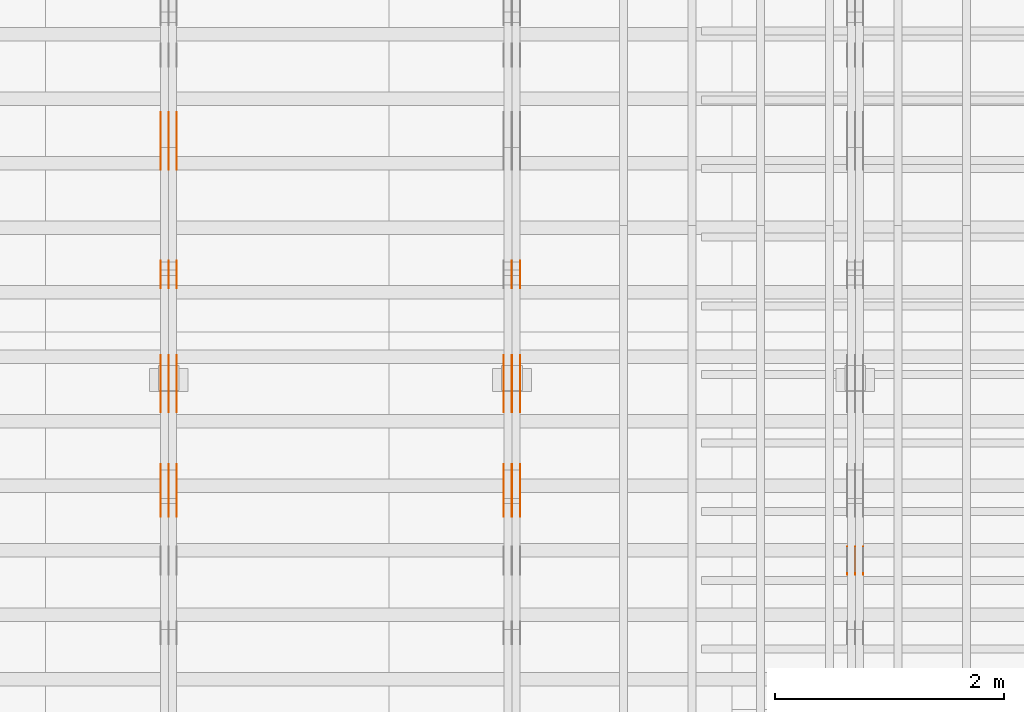
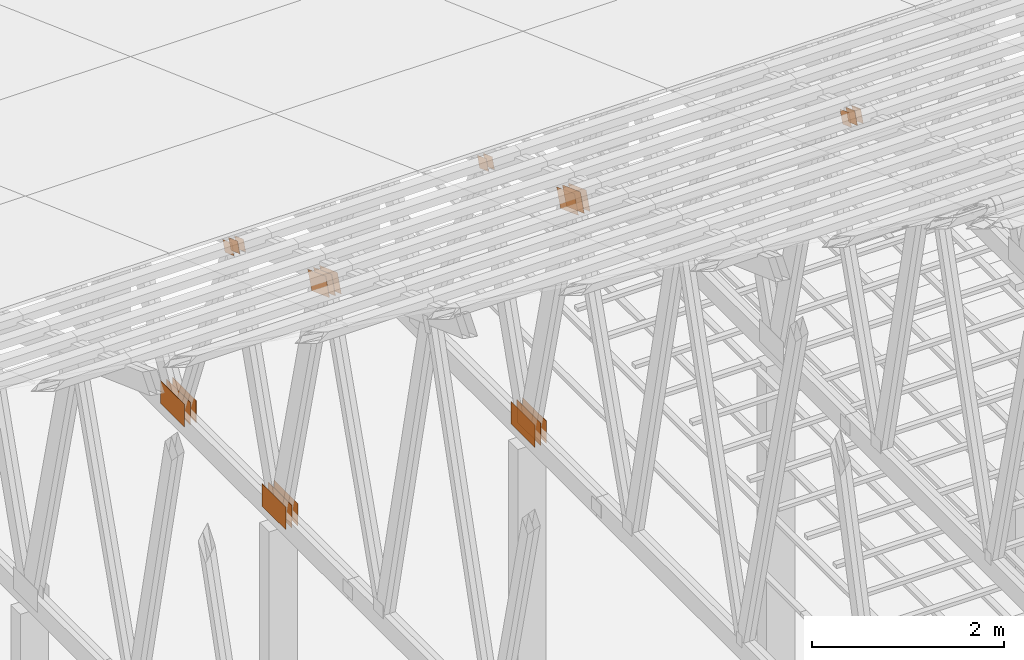
# One storey, part 163 of 189: 30 proxies.
"""IFC2X3 building model written with IfcOpenShell, lengths in millimetres."""

from ifc_helpers import new_model, entity, si_unit, converted_unit, derived_unit, direction, frame, origin, origin_2d_with_axis, place, context, subcontext, project, spatial, polyline, rectangle, outline, extrude, source, transform, mapped, material, type_object, type_shapes, element, save


model = new_model("IFC2X3")

# Units and contexts
model_context = context("Model", 3, precision=0.01, world=origin(), true_north=direction((6.12303176911189e-17, 1.0)))
body_context = subcontext(model_context, "Body", "Model", "MODEL_VIEW")
ifc_project = project(units=[si_unit("LENGTHUNIT", "METRE", prefix="MILLI"), si_unit("AREAUNIT", "SQUARE_METRE"), si_unit("VOLUMEUNIT", "CUBIC_METRE"), converted_unit("PLANEANGLEUNIT", "DEGREE", entity("IfcRatioMeasure", 0.0174532925199433), si_unit("PLANEANGLEUNIT", "RADIAN"), dimensions=[0, 0, 0, 0, 0, 0, 0]), si_unit("MASSUNIT", "GRAM", prefix="KILO"), derived_unit("MASSDENSITYUNIT", [(si_unit("MASSUNIT", "GRAM", prefix="KILO"), 1), (si_unit("LENGTHUNIT", "METRE"), -3)]), si_unit("TIMEUNIT", "SECOND"), si_unit("FREQUENCYUNIT", "HERTZ"), si_unit("THERMODYNAMICTEMPERATUREUNIT", "DEGREE_CELSIUS"), derived_unit("THERMALTRANSMITTANCEUNIT", [(si_unit("MASSUNIT", "GRAM", prefix="KILO"), 1), (si_unit("THERMODYNAMICTEMPERATUREUNIT", "KELVIN"), -1), (si_unit("TIMEUNIT", "SECOND"), -3)]), derived_unit("VOLUMETRICFLOWRATEUNIT", [(si_unit("LENGTHUNIT", "METRE"), 3), (si_unit("TIMEUNIT", "SECOND"), -1)]), si_unit("ELECTRICCURRENTUNIT", "AMPERE"), si_unit("ELECTRICVOLTAGEUNIT", "VOLT"), si_unit("POWERUNIT", "WATT"), si_unit("FORCEUNIT", "NEWTON"), si_unit("ILLUMINANCEUNIT", "LUX"), si_unit("LUMINOUSFLUXUNIT", "LUMEN"), si_unit("LUMINOUSINTENSITYUNIT", "CANDELA"), derived_unit("USERDEFINED", [(si_unit("MASSUNIT", "GRAM", prefix="KILO"), -1), (si_unit("LENGTHUNIT", "METRE"), -2), (si_unit("TIMEUNIT", "SECOND"), 3), (si_unit("LUMINOUSFLUXUNIT", "LUMEN"), 1)]), derived_unit("LINEARVELOCITYUNIT", [(si_unit("LENGTHUNIT", "METRE"), 1), (si_unit("TIMEUNIT", "SECOND"), -1)]), si_unit("PRESSUREUNIT", "PASCAL"), derived_unit("USERDEFINED", [(si_unit("LENGTHUNIT", "METRE"), -2), (si_unit("MASSUNIT", "GRAM", prefix="KILO"), 1), (si_unit("TIMEUNIT", "SECOND"), -2)])], contexts=[model_context])

# Site, building, storey
site_placement = place(None, origin())
site = spatial("IfcSite", under=ifc_project, at=site_placement, CompositionType="ELEMENT")
building_placement = place(site_placement, origin())
building = spatial("IfcBuilding", under=site, at=building_placement, CompositionType="ELEMENT")
storey_placement = place(building_placement, origin())
storey = spatial("IfcBuildingStorey", under=building, at=storey_placement, Name="Default", CompositionType="ELEMENT", Elevation=0.0)

# Proxies
ifc_material_1 = material(Name="IfcSurfaceStyle #242780")
building_element_proxy_type_1 = type_object("IfcBuildingElementProxyType", PredefinedType="NOTDEFINED", material=ifc_material_1)
shared_shape_1 = source(origin(), body_context, "Body", "SweptSolid", [
    extrude(outline(polyline([(-100.000115120732, -83.9999347094754), (99.9997648860521, -83.9999347094754), (100.000156871236, 83.9999347094753), (-99.9998066365565, 83.9999347094753), (-100.000115120732, -83.9999347094754)])), frame((100.000156871236, 84.0000502182443, 0.0), z_axis=(0.0, 0.0, 1.0), x_axis=(-1.0, 0.0, 0.0)), (0.0, 0.0, 1.0), 1.3),
])
type_shapes(building_element_proxy_type_1, [shared_shape_1])
proxy_1_placement = place(building_placement, frame((45301.3, 19216.0995831719, 3923.28093386695), z_axis=(-1.0, 0.0, 0.0), x_axis=(0.0, -0.939692620785908, 0.342020143325669)))
element("IfcBuildingElementProxy", 1, at=proxy_1_placement, inside=storey, type_object=building_element_proxy_type_1, material=ifc_material_1, context=body_context, shape_type="MappedRepresentation", body=[
    mapped(shared_shape_1, transform((0.0, 0.0, 0.0), scale=1.0)),
])
ifc_material_2 = material(Name="IfcSurfaceStyle #242723")
building_element_proxy_type_2 = type_object("IfcBuildingElementProxyType", PredefinedType="NOTDEFINED", material=ifc_material_2)
shared_shape_2 = source(origin(), body_context, "Body", "SweptSolid", [
    extrude(outline(polyline([(-100.000115120732, -83.9999347094754), (99.9997648860521, -83.9999347094754), (100.000156871236, 83.9999347094753), (-99.9998066365565, 83.9999347094753), (-100.000115120732, -83.9999347094754)])), frame((100.000156871236, 84.0000502182443, 0.0), z_axis=(0.0, 0.0, 1.0), x_axis=(-1.0, 0.0, 0.0)), (0.0, 0.0, 1.0), 1.29999999999998),
])
type_shapes(building_element_proxy_type_2, [shared_shape_2])
proxy_2_placement = place(building_placement, frame((45230.0, 19216.0995831719, 3923.28093386695), z_axis=(-1.0, 0.0, 0.0), x_axis=(0.0, -0.939692620785908, 0.342020143325669)))
element("IfcBuildingElementProxy", 2, at=proxy_2_placement, inside=storey, type_object=building_element_proxy_type_2, material=ifc_material_2, context=body_context, shape_type="MappedRepresentation", body=[
    mapped(shared_shape_2, transform((0.0, 0.0, 0.0), scale=1.0)),
])
ifc_material_3 = material(Name="IfcSurfaceStyle #242666")
building_element_proxy_type_3 = type_object("IfcBuildingElementProxyType", PredefinedType="NOTDEFINED", material=ifc_material_3)
shared_shape_3 = source(origin(), body_context, "Body", "SweptSolid", [
    extrude(outline(polyline([(-100.000115120732, -83.9999347094754), (99.9997648860521, -83.9999347094754), (100.000156871236, 83.9999347094753), (-99.9998066365565, 83.9999347094753), (-100.000115120732, -83.9999347094754)])), frame((100.000156871236, 84.0000502182443, 0.0), z_axis=(0.0, 0.0, 1.0), x_axis=(-1.0, 0.0, 0.0)), (0.0, 0.0, 1.0), 1.29999999999998),
])
type_shapes(building_element_proxy_type_3, [shared_shape_3])
proxy_3_placement = place(building_placement, frame((45231.3, 19216.0995831719, 3923.28093386695), z_axis=(-1.0, 0.0, 0.0), x_axis=(0.0, -0.939692620785908, 0.342020143325669)))
element("IfcBuildingElementProxy", 3, at=proxy_3_placement, inside=storey, type_object=building_element_proxy_type_3, material=ifc_material_3, context=body_context, shape_type="MappedRepresentation", body=[
    mapped(shared_shape_3, transform((0.0, 0.0, 0.0), scale=1.0)),
])
ifc_material_4 = material(Name="IfcSurfaceStyle #242609")
building_element_proxy_type_4 = type_object("IfcBuildingElementProxyType", PredefinedType="NOTDEFINED", material=ifc_material_4)
shared_shape_4 = source(origin(), body_context, "Body", "SweptSolid", [
    extrude(outline(polyline([(-100.000115120732, -83.9999347094754), (99.9997648860521, -83.9999347094754), (100.000156871236, 83.9999347094753), (-99.9998066365565, 83.9999347094753), (-100.000115120732, -83.9999347094754)])), frame((100.000156871236, 84.0000502182443, 0.0), z_axis=(0.0, 0.0, 1.0), x_axis=(-1.0, 0.0, 0.0)), (0.0, 0.0, 1.0), 1.29999999999999),
])
type_shapes(building_element_proxy_type_4, [shared_shape_4])
proxy_4_placement = place(building_placement, frame((45160.0, 19216.0995831719, 3923.28093386695), z_axis=(-1.0, 0.0, 0.0), x_axis=(0.0, -0.939692620785908, 0.342020143325669)))
element("IfcBuildingElementProxy", 4, at=proxy_4_placement, inside=storey, type_object=building_element_proxy_type_4, material=ifc_material_4, context=body_context, shape_type="MappedRepresentation", body=[
    mapped(shared_shape_4, transform((0.0, 0.0, 0.0), scale=1.0)),
])
ifc_material_5 = material(Name="IfcSurfaceStyle #234394")
building_element_proxy_type_5 = type_object("IfcBuildingElementProxyType", PredefinedType="NOTDEFINED", material=ifc_material_5)
shared_shape_5 = source(origin(), body_context, "Body", "SweptSolid", [
    extrude(outline(polyline([(-200.000344770935, -119.999765965113), (199.999582244654, -119.999765965113), (200.000344770935, 119.999765965113), (-199.999582244653, 119.999765965113), (-200.000344770935, -119.999765965113)])), frame((200.000344770935, 119.999990805307, 0.0), z_axis=(0.0, 0.0, 1.0), x_axis=(-1.0, 0.0, 0.0)), (0.0, 0.0, 1.0), 1.29999999999999),
])
type_shapes(building_element_proxy_type_5, [shared_shape_5])
proxy_5_placement = place(building_placement, frame((42301.3, 19620.1777846684, 3837.77137841443), z_axis=(-1.0, 0.0, 0.0), x_axis=(0.0, 0.939692620785908, -0.342020143325669)))
element("IfcBuildingElementProxy", 5, at=proxy_5_placement, inside=storey, type_object=building_element_proxy_type_5, material=ifc_material_5, context=body_context, shape_type="MappedRepresentation", body=[
    mapped(shared_shape_5, transform((0.0, 0.0, 0.0), scale=1.0)),
])
ifc_material_6 = material(Name="IfcSurfaceStyle #234337")
building_element_proxy_type_6 = type_object("IfcBuildingElementProxyType", PredefinedType="NOTDEFINED", material=ifc_material_6)
shared_shape_6 = source(origin(), body_context, "Body", "SweptSolid", [
    extrude(outline(polyline([(-200.000344770935, -119.999765965113), (199.999582244654, -119.999765965113), (200.000344770935, 119.999765965113), (-199.999582244653, 119.999765965113), (-200.000344770935, -119.999765965113)])), frame((200.000344770935, 119.999990805307, 0.0), z_axis=(0.0, 0.0, 1.0), x_axis=(-1.0, 0.0, 0.0)), (0.0, 0.0, 1.0), 1.29999999999997),
])
type_shapes(building_element_proxy_type_6, [shared_shape_6])
proxy_6_placement = place(building_placement, frame((42230.0, 19620.1777846684, 3837.77137841443), z_axis=(-1.0, 0.0, 0.0), x_axis=(0.0, 0.939692620785908, -0.342020143325669)))
element("IfcBuildingElementProxy", 6, at=proxy_6_placement, inside=storey, type_object=building_element_proxy_type_6, material=ifc_material_6, context=body_context, shape_type="MappedRepresentation", body=[
    mapped(shared_shape_6, transform((0.0, 0.0, 0.0), scale=1.0)),
])
ifc_material_7 = material(Name="IfcSurfaceStyle #234280")
building_element_proxy_type_7 = type_object("IfcBuildingElementProxyType", PredefinedType="NOTDEFINED", material=ifc_material_7)
shared_shape_7 = source(origin(), body_context, "Body", "SweptSolid", [
    extrude(outline(polyline([(-200.000344770935, -119.999765965113), (199.999582244654, -119.999765965113), (200.000344770935, 119.999765965113), (-199.999582244653, 119.999765965113), (-200.000344770935, -119.999765965113)])), frame((200.000344770935, 119.999990805307, 0.0), z_axis=(0.0, 0.0, 1.0), x_axis=(-1.0, 0.0, 0.0)), (0.0, 0.0, 1.0), 1.29999999999997),
])
type_shapes(building_element_proxy_type_7, [shared_shape_7])
proxy_7_placement = place(building_placement, frame((42231.3, 19620.1777846684, 3837.77137841443), z_axis=(-1.0, 0.0, 0.0), x_axis=(0.0, 0.939692620785908, -0.342020143325669)))
element("IfcBuildingElementProxy", 7, at=proxy_7_placement, inside=storey, type_object=building_element_proxy_type_7, material=ifc_material_7, context=body_context, shape_type="MappedRepresentation", body=[
    mapped(shared_shape_7, transform((0.0, 0.0, 0.0), scale=1.0)),
])
ifc_material_8 = material(Name="IfcSurfaceStyle #234223")
building_element_proxy_type_8 = type_object("IfcBuildingElementProxyType", PredefinedType="NOTDEFINED", material=ifc_material_8)
shared_shape_8 = source(origin(), body_context, "Body", "SweptSolid", [
    extrude(outline(polyline([(-200.000344770935, -119.999765965113), (199.999582244654, -119.999765965113), (200.000344770935, 119.999765965113), (-199.999582244653, 119.999765965113), (-200.000344770935, -119.999765965113)])), frame((200.000344770935, 119.999990805307, 0.0), z_axis=(0.0, 0.0, 1.0), x_axis=(-1.0, 0.0, 0.0)), (0.0, 0.0, 1.0), 1.29999999999998),
])
type_shapes(building_element_proxy_type_8, [shared_shape_8])
proxy_8_placement = place(building_placement, frame((42160.0, 19620.1777846684, 3837.77137841443), z_axis=(-1.0, 0.0, 0.0), x_axis=(0.0, 0.939692620785908, -0.342020143325669)))
element("IfcBuildingElementProxy", 8, at=proxy_8_placement, inside=storey, type_object=building_element_proxy_type_8, material=ifc_material_8, context=body_context, shape_type="MappedRepresentation", body=[
    mapped(shared_shape_8, transform((0.0, 0.0, 0.0), scale=1.0)),
])
ifc_material_9 = material(Name="IfcSurfaceStyle #234166")
building_element_proxy_type_9 = type_object("IfcBuildingElementProxyType", PredefinedType="NOTDEFINED", material=ifc_material_9)
shared_shape_9 = source(origin(), body_context, "Body", "SweptSolid", [
    extrude(rectangle(XDim=500.0, YDim=288.0, at=origin_2d_with_axis()), frame((250.0, 144.0, 0.0), z_axis=(0.0, 0.0, 1.0), x_axis=(-1.0, 0.0, 0.0)), (0.0, 0.0, 1.0), 1.29999999999998),
])
type_shapes(building_element_proxy_type_9, [shared_shape_9])
proxy_9_placement = place(building_placement, frame((42301.3, 20948.0908203125, 101.0), z_axis=(-1.0, 0.0, 0.0), x_axis=(0.0, -1.0, 0.0)))
element("IfcBuildingElementProxy", 9, at=proxy_9_placement, inside=storey, type_object=building_element_proxy_type_9, material=ifc_material_9, context=body_context, shape_type="MappedRepresentation", body=[
    mapped(shared_shape_9, transform((0.0, 0.0, 0.0), scale=1.0)),
])
ifc_material_10 = material(Name="IfcSurfaceStyle #234109")
building_element_proxy_type_10 = type_object("IfcBuildingElementProxyType", PredefinedType="NOTDEFINED", material=ifc_material_10)
shared_shape_10 = source(origin(), body_context, "Body", "SweptSolid", [
    extrude(rectangle(XDim=500.0, YDim=288.0, at=origin_2d_with_axis()), frame((250.0, 144.0, 0.0), z_axis=(0.0, 0.0, 1.0), x_axis=(-1.0, 0.0, 0.0)), (0.0, 0.0, 1.0), 1.29999999999997),
])
type_shapes(building_element_proxy_type_10, [shared_shape_10])
proxy_10_placement = place(building_placement, frame((42230.0, 20948.0908203125, 101.0), z_axis=(-1.0, 0.0, 0.0), x_axis=(0.0, -1.0, 0.0)))
element("IfcBuildingElementProxy", 10, at=proxy_10_placement, inside=storey, type_object=building_element_proxy_type_10, material=ifc_material_10, context=body_context, shape_type="MappedRepresentation", body=[
    mapped(shared_shape_10, transform((0.0, 0.0, 0.0), scale=1.0)),
])
ifc_material_11 = material(Name="IfcSurfaceStyle #234052")
building_element_proxy_type_11 = type_object("IfcBuildingElementProxyType", PredefinedType="NOTDEFINED", material=ifc_material_11)
shared_shape_11 = source(origin(), body_context, "Body", "SweptSolid", [
    extrude(rectangle(XDim=500.0, YDim=288.0, at=origin_2d_with_axis()), frame((250.0, 144.0, 0.0), z_axis=(0.0, 0.0, 1.0), x_axis=(-1.0, 0.0, 0.0)), (0.0, 0.0, 1.0), 1.29999999999997),
])
type_shapes(building_element_proxy_type_11, [shared_shape_11])
proxy_11_placement = place(building_placement, frame((42231.3, 20948.0908203125, 101.0), z_axis=(-1.0, 0.0, 0.0), x_axis=(0.0, -1.0, 0.0)))
element("IfcBuildingElementProxy", 11, at=proxy_11_placement, inside=storey, type_object=building_element_proxy_type_11, material=ifc_material_11, context=body_context, shape_type="MappedRepresentation", body=[
    mapped(shared_shape_11, transform((0.0, 0.0, 0.0), scale=1.0)),
])
ifc_material_12 = material(Name="IfcSurfaceStyle #233995")
building_element_proxy_type_12 = type_object("IfcBuildingElementProxyType", PredefinedType="NOTDEFINED", material=ifc_material_12)
shared_shape_12 = source(origin(), body_context, "Body", "SweptSolid", [
    extrude(rectangle(XDim=500.0, YDim=288.0, at=origin_2d_with_axis()), frame((250.0, 144.0, 0.0), z_axis=(0.0, 0.0, 1.0), x_axis=(-1.0, 0.0, 0.0)), (0.0, 0.0, 1.0), 1.29999999999997),
])
type_shapes(building_element_proxy_type_12, [shared_shape_12])
proxy_12_placement = place(building_placement, frame((42160.0, 20948.0908203125, 101.0), z_axis=(-1.0, 0.0, 0.0), x_axis=(0.0, -1.0, 0.0)))
element("IfcBuildingElementProxy", 12, at=proxy_12_placement, inside=storey, type_object=building_element_proxy_type_12, material=ifc_material_12, context=body_context, shape_type="MappedRepresentation", body=[
    mapped(shared_shape_12, transform((0.0, 0.0, 0.0), scale=1.0)),
])
ifc_material_13 = material(Name="IfcSurfaceStyle #233482")
building_element_proxy_type_13 = type_object("IfcBuildingElementProxyType", PredefinedType="NOTDEFINED", material=ifc_material_13)
shared_shape_13 = source(origin(), body_context, "Body", "SweptSolid", [
    extrude(outline(polyline([(-100.000279336925, -71.9999636698844), (100.000143005157, -71.9999636698844), (100.00004991978, 71.9999636698844), (-99.9999135880125, 71.9999636698845), (-100.000279336925, -71.9999636698844)])), frame((100.000143005157, 72.0001110824169, 0.0), z_axis=(0.0, 0.0, 1.0), x_axis=(-1.0, 0.0, 0.0)), (0.0, 0.0, 1.0), 1.3),
])
type_shapes(building_element_proxy_type_13, [shared_shape_13])
proxy_13_placement = place(building_placement, frame((42301.3, 21584.0819808932, 3071.51551466861), z_axis=(-1.0, 0.0, 0.0), x_axis=(0.0, 0.939692620785908, -0.342020143325669)))
element("IfcBuildingElementProxy", 13, at=proxy_13_placement, inside=storey, type_object=building_element_proxy_type_13, material=ifc_material_13, context=body_context, shape_type="MappedRepresentation", body=[
    mapped(shared_shape_13, transform((0.0, 0.0, 0.0), scale=1.0)),
])
ifc_material_14 = material(Name="IfcSurfaceStyle #233425")
building_element_proxy_type_14 = type_object("IfcBuildingElementProxyType", PredefinedType="NOTDEFINED", material=ifc_material_14)
shared_shape_14 = source(origin(), body_context, "Body", "SweptSolid", [
    extrude(outline(polyline([(-100.000279336925, -71.9999636698844), (100.000143005157, -71.9999636698844), (100.00004991978, 71.9999636698844), (-99.9999135880125, 71.9999636698845), (-100.000279336925, -71.9999636698844)])), frame((100.000143005157, 72.0001110824169, 0.0), z_axis=(0.0, 0.0, 1.0), x_axis=(-1.0, 0.0, 0.0)), (0.0, 0.0, 1.0), 1.29999999999998),
])
type_shapes(building_element_proxy_type_14, [shared_shape_14])
proxy_14_placement = place(building_placement, frame((42230.0, 21584.0819808932, 3071.51551466861), z_axis=(-1.0, 0.0, 0.0), x_axis=(0.0, 0.939692620785908, -0.342020143325669)))
element("IfcBuildingElementProxy", 14, at=proxy_14_placement, inside=storey, type_object=building_element_proxy_type_14, material=ifc_material_14, context=body_context, shape_type="MappedRepresentation", body=[
    mapped(shared_shape_14, transform((0.0, 0.0, 0.0), scale=1.0)),
])
ifc_material_15 = material(Name="IfcSurfaceStyle #218604")
building_element_proxy_type_15 = type_object("IfcBuildingElementProxyType", PredefinedType="NOTDEFINED", material=ifc_material_15)
shared_shape_15 = source(origin(), body_context, "Body", "SweptSolid", [
    extrude(outline(polyline([(-200.000344770935, -119.999765965113), (199.999582244654, -119.999765965113), (200.000344770935, 119.999765965113), (-199.999582244653, 119.999765965113), (-200.000344770935, -119.999765965113)])), frame((200.000344770935, 119.999990805307, 0.0), z_axis=(0.0, 0.0, 1.0), x_axis=(-1.0, 0.0, 0.0)), (0.0, 0.0, 1.0), 1.29999999999999),
])
type_shapes(building_element_proxy_type_15, [shared_shape_15])
proxy_15_placement = place(building_placement, frame((39301.3, 19620.1777846684, 3837.77137841443), z_axis=(-1.0, 0.0, 0.0), x_axis=(0.0, 0.939692620785908, -0.342020143325669)))
element("IfcBuildingElementProxy", 15, at=proxy_15_placement, inside=storey, type_object=building_element_proxy_type_15, material=ifc_material_15, context=body_context, shape_type="MappedRepresentation", body=[
    mapped(shared_shape_15, transform((0.0, 0.0, 0.0), scale=1.0)),
])
ifc_material_16 = material(Name="IfcSurfaceStyle #218547")
building_element_proxy_type_16 = type_object("IfcBuildingElementProxyType", PredefinedType="NOTDEFINED", material=ifc_material_16)
shared_shape_16 = source(origin(), body_context, "Body", "SweptSolid", [
    extrude(outline(polyline([(-200.000344770935, -119.999765965113), (199.999582244654, -119.999765965113), (200.000344770935, 119.999765965113), (-199.999582244653, 119.999765965113), (-200.000344770935, -119.999765965113)])), frame((200.000344770935, 119.999990805307, 0.0), z_axis=(0.0, 0.0, 1.0), x_axis=(-1.0, 0.0, 0.0)), (0.0, 0.0, 1.0), 1.29999999999997),
])
type_shapes(building_element_proxy_type_16, [shared_shape_16])
proxy_16_placement = place(building_placement, frame((39230.0, 19620.1777846684, 3837.77137841443), z_axis=(-1.0, 0.0, 0.0), x_axis=(0.0, 0.939692620785908, -0.342020143325669)))
element("IfcBuildingElementProxy", 16, at=proxy_16_placement, inside=storey, type_object=building_element_proxy_type_16, material=ifc_material_16, context=body_context, shape_type="MappedRepresentation", body=[
    mapped(shared_shape_16, transform((0.0, 0.0, 0.0), scale=1.0)),
])
ifc_material_17 = material(Name="IfcSurfaceStyle #218490")
building_element_proxy_type_17 = type_object("IfcBuildingElementProxyType", PredefinedType="NOTDEFINED", material=ifc_material_17)
shared_shape_17 = source(origin(), body_context, "Body", "SweptSolid", [
    extrude(outline(polyline([(-200.000344770935, -119.999765965113), (199.999582244654, -119.999765965113), (200.000344770935, 119.999765965113), (-199.999582244653, 119.999765965113), (-200.000344770935, -119.999765965113)])), frame((200.000344770935, 119.999990805307, 0.0), z_axis=(0.0, 0.0, 1.0), x_axis=(-1.0, 0.0, 0.0)), (0.0, 0.0, 1.0), 1.29999999999997),
])
type_shapes(building_element_proxy_type_17, [shared_shape_17])
proxy_17_placement = place(building_placement, frame((39231.3, 19620.1777846684, 3837.77137841443), z_axis=(-1.0, 0.0, 0.0), x_axis=(0.0, 0.939692620785908, -0.342020143325669)))
element("IfcBuildingElementProxy", 17, at=proxy_17_placement, inside=storey, type_object=building_element_proxy_type_17, material=ifc_material_17, context=body_context, shape_type="MappedRepresentation", body=[
    mapped(shared_shape_17, transform((0.0, 0.0, 0.0), scale=1.0)),
])
ifc_material_18 = material(Name="IfcSurfaceStyle #218433")
building_element_proxy_type_18 = type_object("IfcBuildingElementProxyType", PredefinedType="NOTDEFINED", material=ifc_material_18)
shared_shape_18 = source(origin(), body_context, "Body", "SweptSolid", [
    extrude(outline(polyline([(-200.000344770935, -119.999765965113), (199.999582244654, -119.999765965113), (200.000344770935, 119.999765965113), (-199.999582244653, 119.999765965113), (-200.000344770935, -119.999765965113)])), frame((200.000344770935, 119.999990805307, 0.0), z_axis=(0.0, 0.0, 1.0), x_axis=(-1.0, 0.0, 0.0)), (0.0, 0.0, 1.0), 1.29999999999998),
])
type_shapes(building_element_proxy_type_18, [shared_shape_18])
proxy_18_placement = place(building_placement, frame((39160.0, 19620.1777846684, 3837.77137841443), z_axis=(-1.0, 0.0, 0.0), x_axis=(0.0, 0.939692620785908, -0.342020143325669)))
element("IfcBuildingElementProxy", 18, at=proxy_18_placement, inside=storey, type_object=building_element_proxy_type_18, material=ifc_material_18, context=body_context, shape_type="MappedRepresentation", body=[
    mapped(shared_shape_18, transform((0.0, 0.0, 0.0), scale=1.0)),
])
ifc_material_19 = material(Name="IfcSurfaceStyle #218376")
building_element_proxy_type_19 = type_object("IfcBuildingElementProxyType", PredefinedType="NOTDEFINED", material=ifc_material_19)
shared_shape_19 = source(origin(), body_context, "Body", "SweptSolid", [
    extrude(rectangle(XDim=500.0, YDim=288.0, at=origin_2d_with_axis()), frame((250.0, 144.0, 0.0), z_axis=(0.0, 0.0, 1.0), x_axis=(-1.0, 0.0, 0.0)), (0.0, 0.0, 1.0), 1.29999999999998),
])
type_shapes(building_element_proxy_type_19, [shared_shape_19])
proxy_19_placement = place(building_placement, frame((39301.3, 20948.0908203125, 101.0), z_axis=(-1.0, 0.0, 0.0), x_axis=(0.0, -1.0, 0.0)))
element("IfcBuildingElementProxy", 19, at=proxy_19_placement, inside=storey, type_object=building_element_proxy_type_19, material=ifc_material_19, context=body_context, shape_type="MappedRepresentation", body=[
    mapped(shared_shape_19, transform((0.0, 0.0, 0.0), scale=1.0)),
])
ifc_material_20 = material(Name="IfcSurfaceStyle #218319")
building_element_proxy_type_20 = type_object("IfcBuildingElementProxyType", PredefinedType="NOTDEFINED", material=ifc_material_20)
shared_shape_20 = source(origin(), body_context, "Body", "SweptSolid", [
    extrude(rectangle(XDim=500.0, YDim=288.0, at=origin_2d_with_axis()), frame((250.0, 144.0, 0.0), z_axis=(0.0, 0.0, 1.0), x_axis=(-1.0, 0.0, 0.0)), (0.0, 0.0, 1.0), 1.29999999999997),
])
type_shapes(building_element_proxy_type_20, [shared_shape_20])
proxy_20_placement = place(building_placement, frame((39230.0, 20948.0908203125, 101.0), z_axis=(-1.0, 0.0, 0.0), x_axis=(0.0, -1.0, 0.0)))
element("IfcBuildingElementProxy", 20, at=proxy_20_placement, inside=storey, type_object=building_element_proxy_type_20, material=ifc_material_20, context=body_context, shape_type="MappedRepresentation", body=[
    mapped(shared_shape_20, transform((0.0, 0.0, 0.0), scale=1.0)),
])
ifc_material_21 = material(Name="IfcSurfaceStyle #218262")
building_element_proxy_type_21 = type_object("IfcBuildingElementProxyType", PredefinedType="NOTDEFINED", material=ifc_material_21)
shared_shape_21 = source(origin(), body_context, "Body", "SweptSolid", [
    extrude(rectangle(XDim=500.0, YDim=288.0, at=origin_2d_with_axis()), frame((250.0, 144.0, 0.0), z_axis=(0.0, 0.0, 1.0), x_axis=(-1.0, 0.0, 0.0)), (0.0, 0.0, 1.0), 1.29999999999997),
])
type_shapes(building_element_proxy_type_21, [shared_shape_21])
proxy_21_placement = place(building_placement, frame((39231.3, 20948.0908203125, 101.0), z_axis=(-1.0, 0.0, 0.0), x_axis=(0.0, -1.0, 0.0)))
element("IfcBuildingElementProxy", 21, at=proxy_21_placement, inside=storey, type_object=building_element_proxy_type_21, material=ifc_material_21, context=body_context, shape_type="MappedRepresentation", body=[
    mapped(shared_shape_21, transform((0.0, 0.0, 0.0), scale=1.0)),
])
ifc_material_22 = material(Name="IfcSurfaceStyle #218205")
building_element_proxy_type_22 = type_object("IfcBuildingElementProxyType", PredefinedType="NOTDEFINED", material=ifc_material_22)
shared_shape_22 = source(origin(), body_context, "Body", "SweptSolid", [
    extrude(rectangle(XDim=500.0, YDim=288.0, at=origin_2d_with_axis()), frame((250.0, 144.0, 0.0), z_axis=(0.0, 0.0, 1.0), x_axis=(-1.0, 0.0, 0.0)), (0.0, 0.0, 1.0), 1.29999999999997),
])
type_shapes(building_element_proxy_type_22, [shared_shape_22])
proxy_22_placement = place(building_placement, frame((39160.0, 20948.0908203125, 101.0), z_axis=(-1.0, 0.0, 0.0), x_axis=(0.0, -1.0, 0.0)))
element("IfcBuildingElementProxy", 22, at=proxy_22_placement, inside=storey, type_object=building_element_proxy_type_22, material=ifc_material_22, context=body_context, shape_type="MappedRepresentation", body=[
    mapped(shared_shape_22, transform((0.0, 0.0, 0.0), scale=1.0)),
])
ifc_material_23 = material(Name="IfcSurfaceStyle #217692")
building_element_proxy_type_23 = type_object("IfcBuildingElementProxyType", PredefinedType="NOTDEFINED", material=ifc_material_23)
shared_shape_23 = source(origin(), body_context, "Body", "SweptSolid", [
    extrude(outline(polyline([(-100.000279336925, -71.9999636698844), (100.000143005157, -71.9999636698844), (100.00004991978, 71.9999636698844), (-99.9999135880125, 71.9999636698845), (-100.000279336925, -71.9999636698844)])), frame((100.000143005157, 72.0001110824169, 0.0), z_axis=(0.0, 0.0, 1.0), x_axis=(-1.0, 0.0, 0.0)), (0.0, 0.0, 1.0), 1.3),
])
type_shapes(building_element_proxy_type_23, [shared_shape_23])
proxy_23_placement = place(building_placement, frame((39301.3, 21584.0819808932, 3071.51551466861), z_axis=(-1.0, 0.0, 0.0), x_axis=(0.0, 0.939692620785908, -0.342020143325669)))
element("IfcBuildingElementProxy", 23, at=proxy_23_placement, inside=storey, type_object=building_element_proxy_type_23, material=ifc_material_23, context=body_context, shape_type="MappedRepresentation", body=[
    mapped(shared_shape_23, transform((0.0, 0.0, 0.0), scale=1.0)),
])
ifc_material_24 = material(Name="IfcSurfaceStyle #217635")
building_element_proxy_type_24 = type_object("IfcBuildingElementProxyType", PredefinedType="NOTDEFINED", material=ifc_material_24)
shared_shape_24 = source(origin(), body_context, "Body", "SweptSolid", [
    extrude(outline(polyline([(-100.000279336925, -71.9999636698844), (100.000143005157, -71.9999636698844), (100.00004991978, 71.9999636698844), (-99.9999135880125, 71.9999636698845), (-100.000279336925, -71.9999636698844)])), frame((100.000143005157, 72.0001110824169, 0.0), z_axis=(0.0, 0.0, 1.0), x_axis=(-1.0, 0.0, 0.0)), (0.0, 0.0, 1.0), 1.29999999999998),
])
type_shapes(building_element_proxy_type_24, [shared_shape_24])
proxy_24_placement = place(building_placement, frame((39230.0, 21584.0819808932, 3071.51551466861), z_axis=(-1.0, 0.0, 0.0), x_axis=(0.0, 0.939692620785908, -0.342020143325669)))
element("IfcBuildingElementProxy", 24, at=proxy_24_placement, inside=storey, type_object=building_element_proxy_type_24, material=ifc_material_24, context=body_context, shape_type="MappedRepresentation", body=[
    mapped(shared_shape_24, transform((0.0, 0.0, 0.0), scale=1.0)),
])
ifc_material_25 = material(Name="IfcSurfaceStyle #217578")
building_element_proxy_type_25 = type_object("IfcBuildingElementProxyType", PredefinedType="NOTDEFINED", material=ifc_material_25)
shared_shape_25 = source(origin(), body_context, "Body", "SweptSolid", [
    extrude(outline(polyline([(-100.000279336925, -71.9999636698844), (100.000143005157, -71.9999636698844), (100.00004991978, 71.9999636698844), (-99.9999135880125, 71.9999636698845), (-100.000279336925, -71.9999636698844)])), frame((100.000143005157, 72.0001110824169, 0.0), z_axis=(0.0, 0.0, 1.0), x_axis=(-1.0, 0.0, 0.0)), (0.0, 0.0, 1.0), 1.29999999999998),
])
type_shapes(building_element_proxy_type_25, [shared_shape_25])
proxy_25_placement = place(building_placement, frame((39231.3, 21584.0819808932, 3071.51551466861), z_axis=(-1.0, 0.0, 0.0), x_axis=(0.0, 0.939692620785908, -0.342020143325669)))
element("IfcBuildingElementProxy", 25, at=proxy_25_placement, inside=storey, type_object=building_element_proxy_type_25, material=ifc_material_25, context=body_context, shape_type="MappedRepresentation", body=[
    mapped(shared_shape_25, transform((0.0, 0.0, 0.0), scale=1.0)),
])
ifc_material_26 = material(Name="IfcSurfaceStyle #217521")
building_element_proxy_type_26 = type_object("IfcBuildingElementProxyType", PredefinedType="NOTDEFINED", material=ifc_material_26)
shared_shape_26 = source(origin(), body_context, "Body", "SweptSolid", [
    extrude(outline(polyline([(-100.000279336925, -71.9999636698844), (100.000143005157, -71.9999636698844), (100.00004991978, 71.9999636698844), (-99.9999135880125, 71.9999636698845), (-100.000279336925, -71.9999636698844)])), frame((100.000143005157, 72.0001110824169, 0.0), z_axis=(0.0, 0.0, 1.0), x_axis=(-1.0, 0.0, 0.0)), (0.0, 0.0, 1.0), 1.29999999999999),
])
type_shapes(building_element_proxy_type_26, [shared_shape_26])
proxy_26_placement = place(building_placement, frame((39160.0, 21584.0819808932, 3071.51551466861), z_axis=(-1.0, 0.0, 0.0), x_axis=(0.0, 0.939692620785908, -0.342020143325669)))
element("IfcBuildingElementProxy", 26, at=proxy_26_placement, inside=storey, type_object=building_element_proxy_type_26, material=ifc_material_26, context=body_context, shape_type="MappedRepresentation", body=[
    mapped(shared_shape_26, transform((0.0, 0.0, 0.0), scale=1.0)),
])
ifc_material_27 = material(Name="IfcSurfaceStyle #217464")
building_element_proxy_type_27 = type_object("IfcBuildingElementProxyType", PredefinedType="NOTDEFINED", material=ifc_material_27)
shared_shape_27 = source(origin(), body_context, "Body", "SweptSolid", [
    extrude(rectangle(XDim=500.0, YDim=288.000007629395, at=origin_2d_with_axis()), frame((250.000021301719, 144.000006357829, 0.0), z_axis=(0.0, 0.0, 1.0), x_axis=(-1.0, 0.0, 0.0)), (0.0, 0.0, 1.0), 1.29999999999998),
])
type_shapes(building_element_proxy_type_27, [shared_shape_27])
proxy_27_placement = place(building_placement, frame((39301.3, 23069.1650603642, 127.333333333333), z_axis=(-1.0, 0.0, 0.0), x_axis=(0.0, -1.0, 0.0)))
element("IfcBuildingElementProxy", 27, at=proxy_27_placement, inside=storey, type_object=building_element_proxy_type_27, material=ifc_material_27, context=body_context, shape_type="MappedRepresentation", body=[
    mapped(shared_shape_27, transform((0.0, 0.0, 0.0), scale=1.0)),
])
ifc_material_28 = material(Name="IfcSurfaceStyle #217407")
building_element_proxy_type_28 = type_object("IfcBuildingElementProxyType", PredefinedType="NOTDEFINED", material=ifc_material_28)
shared_shape_28 = source(origin(), body_context, "Body", "SweptSolid", [
    extrude(rectangle(XDim=500.0, YDim=288.000007629395, at=origin_2d_with_axis()), frame((250.000021301719, 144.000006357829, 0.0), z_axis=(0.0, 0.0, 1.0), x_axis=(-1.0, 0.0, 0.0)), (0.0, 0.0, 1.0), 1.29999999999997),
])
type_shapes(building_element_proxy_type_28, [shared_shape_28])
proxy_28_placement = place(building_placement, frame((39230.0, 23069.1650603642, 127.333333333333), z_axis=(-1.0, 0.0, 0.0), x_axis=(0.0, -1.0, 0.0)))
element("IfcBuildingElementProxy", 28, at=proxy_28_placement, inside=storey, type_object=building_element_proxy_type_28, material=ifc_material_28, context=body_context, shape_type="MappedRepresentation", body=[
    mapped(shared_shape_28, transform((0.0, 0.0, 0.0), scale=1.0)),
])
ifc_material_29 = material(Name="IfcSurfaceStyle #217350")
building_element_proxy_type_29 = type_object("IfcBuildingElementProxyType", PredefinedType="NOTDEFINED", material=ifc_material_29)
shared_shape_29 = source(origin(), body_context, "Body", "SweptSolid", [
    extrude(rectangle(XDim=500.0, YDim=288.000007629395, at=origin_2d_with_axis()), frame((250.000021301719, 144.000006357829, 0.0), z_axis=(0.0, 0.0, 1.0), x_axis=(-1.0, 0.0, 0.0)), (0.0, 0.0, 1.0), 1.29999999999997),
])
type_shapes(building_element_proxy_type_29, [shared_shape_29])
proxy_29_placement = place(building_placement, frame((39231.3, 23069.1650603642, 127.333333333333), z_axis=(-1.0, 0.0, 0.0), x_axis=(0.0, -1.0, 0.0)))
element("IfcBuildingElementProxy", 29, at=proxy_29_placement, inside=storey, type_object=building_element_proxy_type_29, material=ifc_material_29, context=body_context, shape_type="MappedRepresentation", body=[
    mapped(shared_shape_29, transform((0.0, 0.0, 0.0), scale=1.0)),
])
ifc_material_30 = material(Name="IfcSurfaceStyle #217293")
building_element_proxy_type_30 = type_object("IfcBuildingElementProxyType", PredefinedType="NOTDEFINED", material=ifc_material_30)
shared_shape_30 = source(origin(), body_context, "Body", "SweptSolid", [
    extrude(rectangle(XDim=500.0, YDim=288.000007629395, at=origin_2d_with_axis()), frame((250.000021301719, 144.000006357829, 0.0), z_axis=(0.0, 0.0, 1.0), x_axis=(-1.0, 0.0, 0.0)), (0.0, 0.0, 1.0), 1.29999999999997),
])
type_shapes(building_element_proxy_type_30, [shared_shape_30])
proxy_30_placement = place(building_placement, frame((39160.0, 23069.1650603642, 127.333333333333), z_axis=(-1.0, 0.0, 0.0), x_axis=(0.0, -1.0, 0.0)))
element("IfcBuildingElementProxy", 30, at=proxy_30_placement, inside=storey, type_object=building_element_proxy_type_30, material=ifc_material_30, context=body_context, shape_type="MappedRepresentation", body=[
    mapped(shared_shape_30, transform((0.0, 0.0, 0.0), scale=1.0)),
])

save(model, "model.ifc")
